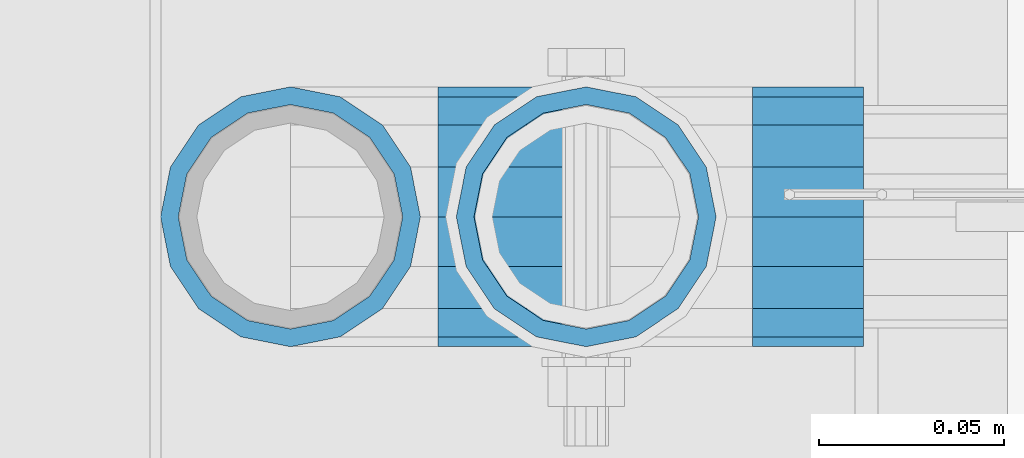
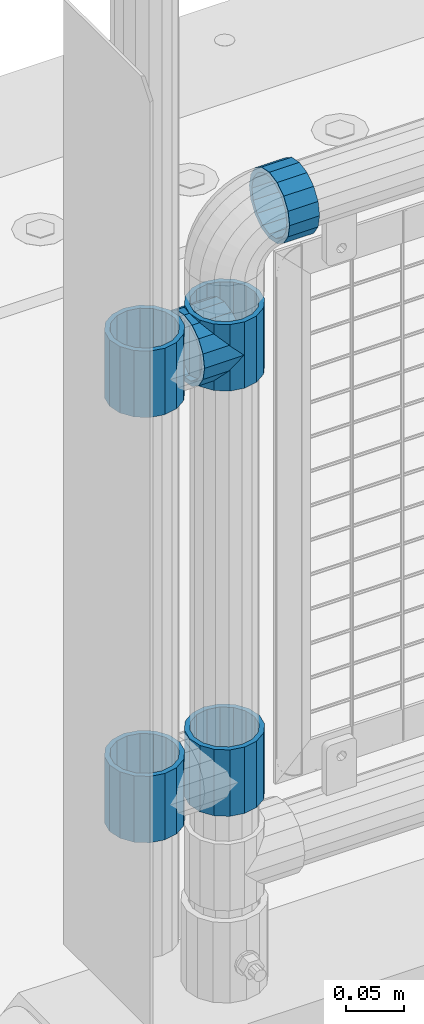
# One storey, part 142 of 242: 6 beams.
"""IFC2X3 building model written with IfcOpenShell, lengths in millimetres."""

import ifcopenshell
import ifcopenshell.guid

model = None  # the IFC model being written
_history = None  # IfcOwnerHistory: only IFC2X3 demands one
_inside = {}  # id of a spatial element -> (the spatial element, [elements in it])
_under = {}  # id of a project, library or spatial element -> (it, [spatial elements below it])
_declared = {}  # id of a project -> (the project, [libraries it declares])
_typed = {}  # id of a type object -> (the type object, [elements of that type])
_made_of = {}  # id of a material, layer set ... -> (it, [elements and type objects made of it])


def new_model(schema):
    """Start an empty IFC model of exactly this schema.

    Asked for "IFC4X3", IfcOpenShell would pick the latest addendum, in which some entities
    have other attributes; the version numbers below select the first issue.
    IFC2X3 requires an IfcOwnerHistory on every rooted entity: one is made here for all.
    """
    global model, _history
    if schema == "IFC4X3":
        model = ifcopenshell.file(schema_version=(4, 3, 0, 0))
    else:
        model = ifcopenshell.file(schema=schema)
    _inside.clear()
    _under.clear()
    _declared.clear()
    _typed.clear()
    _made_of.clear()
    _history = None
    if model.schema == "IFC2X3":
        org = make("IfcOrganization", Name="unknown")
        user = make(
            "IfcPersonAndOrganization",
            ThePerson=make("IfcPerson", FamilyName="unknown"),
            TheOrganization=org,
        )
        app = make(
            "IfcApplication",
            ApplicationDeveloper=org,
            Version="unknown",
            ApplicationFullName="unknown",
            ApplicationIdentifier="unknown",
        )
        _history = make(
            "IfcOwnerHistory",
            OwningUser=user,
            OwningApplication=app,
            ChangeAction="ADDED",
            CreationDate=0,
        )
    return model


def make(cls, **values):
    """One entity of the class cls with the attributes given. An attribute that is None is left unset."""
    return model.create_entity(
        cls, **{name: value for name, value in values.items() if value is not None}
    )


def rooted(cls, **values):
    """An entity with a GlobalId (a new one), such as an element, a storey or a relation."""
    return make(cls, GlobalId=ifcopenshell.guid.new(), OwnerHistory=_history, **values)


def si_unit(unit_type, name, prefix=None):
    """IfcSIUnit, for example si_unit("LENGTHUNIT", "METRE", prefix="MILLI")."""
    return make("IfcSIUnit", UnitType=unit_type, Prefix=prefix, Name=name)


def assignment(units):
    """IfcUnitAssignment: the units of a project."""
    return None if units is None else make("IfcUnitAssignment", Units=units)


def point(xyz):
    """IfcCartesianPoint."""
    return None if xyz is None else make("IfcCartesianPoint", Coordinates=xyz)


def direction(xyz):
    """IfcDirection."""
    return None if xyz is None else make("IfcDirection", DirectionRatios=xyz)


def frame(location, z_axis=None, x_axis=None):
    """IfcAxis2Placement3D, a coordinate frame: its origin and axes. An axis left out is left unset."""
    return make(
        "IfcAxis2Placement3D",
        Location=point(location),
        Axis=direction(z_axis),
        RefDirection=direction(x_axis),
    )


def origin_with_axes():
    """The frame at (0, 0, 0) with the z axis (0, 0, 1) and the x axis (1, 0, 0) written out."""
    return frame((0.0, 0.0, 0.0), z_axis=(0.0, 0.0, 1.0), x_axis=(1.0, 0.0, 0.0))


def place(relative_to, where):
    """IfcLocalPlacement: puts the frame where relative to a parent placement (None: the world)."""
    return make(
        "IfcLocalPlacement", PlacementRelTo=relative_to, RelativePlacement=where
    )


def context(
    kind, dimensions, precision=None, world=None, true_north=None, identifier=None
):
    """IfcGeometricRepresentationContext, for example the 3D "Model" context."""
    return make(
        "IfcGeometricRepresentationContext",
        ContextIdentifier=identifier,
        ContextType=kind,
        CoordinateSpaceDimension=dimensions,
        Precision=precision,
        WorldCoordinateSystem=world,
        TrueNorth=true_north,
    )


def subcontext(parent, identifier, kind, view, scale=None):
    """IfcGeometricRepresentationSubContext, for example "Body" below "Model"."""
    return make(
        "IfcGeometricRepresentationSubContext",
        ContextIdentifier=identifier,
        ContextType=kind,
        ParentContext=parent,
        TargetScale=scale,
        TargetView=view,
    )


def project(units=None, contexts=None):
    """IfcProject with its units and contexts."""
    return rooted(
        "IfcProject",
        Name="project",
        RepresentationContexts=contexts,
        UnitsInContext=assignment(units),
    )


def spatial(cls, under=None, at=None, **own):
    """A site, building, storey or space (cls), placed at a placement, below another one or the project."""
    s = rooted(cls, ObjectPlacement=at, **own)
    if under is not None:
        _under.setdefault(under.id(), (under, []))[1].append(s)
    return s


def faces_of(points, faces, orient=None, outer=None):
    """IfcFace entities. A face is a list of loops; a loop is a list of indices into points, from 0.

    orient and outer hold one flag for each loop. By default every Orientation is true, the
    first loop of a face is its IfcFaceOuterBound and the others are IfcFaceBound.
    """
    made = []
    for i, loops in enumerate(faces):
        bounds = []
        for j, loop in enumerate(loops):
            is_outer = j == 0 if outer is None else outer[i][j]
            bounds.append(
                make(
                    "IfcFaceOuterBound" if is_outer else "IfcFaceBound",
                    Bound=make("IfcPolyLoop", Polygon=[points[k] for k in loop]),
                    Orientation=True if orient is None else orient[i][j],
                )
            )
        made.append(make("IfcFace", Bounds=bounds))
    return made


def faceted_brep(points, faces, orient=None, outer=None, voids=None):
    """IfcFacetedBrep: a solid bounded by flat faces; with voids (closed shells), ...WithVoids."""
    shared = [point(p) for p in points]
    hull = make("IfcClosedShell", CfsFaces=faces_of(shared, faces, orient, outer))
    if voids is None:
        return make("IfcFacetedBrep", Outer=hull)
    return make(
        "IfcFacetedBrepWithVoids",
        Outer=hull,
        Voids=[
            make(cls, CfsFaces=faces_of(shared, fs, o, b)) for cls, fs, o, b in voids
        ],
    )


def shape(context_of_items, identifier, shape_type, items):
    """IfcShapeRepresentation: the items that make up one representation, for example the "Body"."""
    return make(
        "IfcShapeRepresentation",
        ContextOfItems=context_of_items,
        RepresentationIdentifier=identifier,
        RepresentationType=shape_type,
        Items=items,
    )


def material(Name=None, Category=None):
    """IfcMaterial."""
    return make("IfcMaterial", Name=Name, Category=Category)


def made_of(thing, what):
    """Note that an element or type object is made of a material, layer set ...; save() writes the relation."""
    if what is not None:
        _made_of.setdefault(what.id(), (what, []))[1].append(thing)
    return thing


def type_object(cls, material=None, **own):
    """A type object (cls), such as IfcWallType, which elements share."""
    return made_of(rooted(cls, **own), material)


def element(
    cls,
    number,
    at=None,
    inside=None,
    cuts=None,
    type_object=None,
    material=None,
    context=None,
    identifier="Body",
    shape_type=None,
    held_by="IfcProductDefinitionShape",
    body=None,
    shapes=None,
    **own,
):
    """One element of the class cls, such as IfcWall. Its Tag is "e" and its number.

    at: its placement. inside: the storey or other place that contains it. cuts: it is an
    opening in that element (IfcRelVoidsElement). A single representation is given by context,
    identifier, shape_type and body (its items); several are given by shapes. held_by: the class
    of the entity that holds the representations. save() writes the other relations.
    """
    e = rooted(cls, Tag="e%d" % number, ObjectPlacement=at, **own)
    if body is not None:
        shapes = [shape(context, identifier, shape_type, body)]
    if shapes is not None:
        e.Representation = make(held_by, Representations=shapes)
    if inside is not None:
        _inside.setdefault(inside.id(), (inside, []))[1].append(e)
    if cuts is not None:
        rooted(
            "IfcRelVoidsElement", RelatingBuildingElement=cuts, RelatedOpeningElement=e
        )
    if type_object is not None:
        _typed.setdefault(type_object.id(), (type_object, []))[1].append(e)
    return made_of(e, material)


def aggregate(whole, parts):
    """IfcRelAggregates: a whole, such as a stair, and the parts it consists of."""
    return rooted("IfcRelAggregates", RelatingObject=whole, RelatedObjects=parts)


def save(model, path):
    """Write the relations noted so far, then the file.

    IfcRelAggregates (storeys below a building ...), IfcRelContainedInSpatialStructure (elements
    in a storey), IfcRelDefinesByType, IfcRelAssociatesMaterial and IfcRelDeclares: one each for
    every whole, place, type object, material and project.
    """
    for whole, parts in _under.values():
        aggregate(whole, parts)
    for where, things in _inside.values():
        rooted(
            "IfcRelContainedInSpatialStructure",
            RelatedElements=things,
            RelatingStructure=where,
        )
    for kind, things in _typed.values():
        rooted("IfcRelDefinesByType", RelatedObjects=things, RelatingType=kind)
    for what, things in _made_of.values():
        rooted("IfcRelAssociatesMaterial", RelatedObjects=things, RelatingMaterial=what)
    for by, libraries in _declared.values():
        rooted("IfcRelDeclares", RelatingContext=by, RelatedDefinitions=libraries)
    model.write(path)


model = new_model("IFC2X3")

# Units and contexts
model_context = context("Model", 3, precision=1e-05, world=origin_with_axes())
body_context = subcontext(model_context, "Body", "Model", "MODEL_VIEW")
ifc_project = project(units=[si_unit("LENGTHUNIT", "METRE", prefix="MILLI"), si_unit("AREAUNIT", "SQUARE_METRE"), si_unit("VOLUMEUNIT", "CUBIC_METRE"), si_unit("MASSUNIT", "GRAM", prefix="KILO"), si_unit("TIMEUNIT", "SECOND"), si_unit("PLANEANGLEUNIT", "RADIAN"), si_unit("SOLIDANGLEUNIT", "STERADIAN"), si_unit("THERMODYNAMICTEMPERATUREUNIT", "DEGREE_CELSIUS"), si_unit("LUMINOUSINTENSITYUNIT", "LUMEN")], contexts=[model_context])

# Site, building, storey
site_placement = place(None, origin_with_axes())
site = spatial("IfcSite", under=ifc_project, at=site_placement, CompositionType="ELEMENT")
building_placement = place(site_placement, origin_with_axes())
building = spatial("IfcBuilding", under=site, at=building_placement, Name="Standard", CompositionType="ELEMENT")
storey_placement = place(building_placement, origin_with_axes())
storey = spatial("IfcBuildingStorey", under=building, at=storey_placement, Name="Undefined", CompositionType="ELEMENT", Elevation=0.0)

# Beams
ifc_material = material(Name="Misc_Undefined")
beam_type = type_object("IfcBeamType", PredefinedType="NOTDEFINED")
beam_1_placement = place(storey_placement, frame((-41829.0, -19335.5, 848.670000000001), z_axis=(0.0, 1.0, 0.0), x_axis=(-1.0, 0.0, 0.0)))
element("IfcBeam", 1, at=beam_1_placement, inside=storey, type_object=beam_type, material=ifc_material, context=body_context, shape_type="Brep", body=[
    faceted_brep([(0.0, -30.3499999999985, 0.0), (0.0, -28.0397438117179, 11.6144421722784), (40.1500000000015, -28.0397438117175, 11.614442172282), (40.1500000000015, -30.35, 0.0), (0.0, -21.46069080901, 21.4606908090136), (40.1500000000015, -21.4606908090117, 21.46069080901), (0.0, -11.614442172282, 28.0397438117143), (40.1500000000015, -11.6144421722805, 28.0397438117179), (0.0, 0.0, 30.3499999999985), (40.1500000000015, 0.0, 30.3499999999985), (0.0, 11.614442172282, 28.0397438117143), (40.1500000000015, 11.6144421722805, 28.0397438117179), (0.0, 21.46069080901, 21.4606908090136), (40.1500000000015, 21.4606908090117, 21.46069080901), (0.0, 28.0397438117179, 11.6144421722784), (40.1500000000015, 28.0397438117175, 11.614442172282), (0.0, 30.3499999999985, 0.0), (40.1500000000015, 30.35, 0.0), (0.0, 28.0397438117179, -11.6144421722784), (40.1500000000015, 28.0397438117175, -11.614442172282), (0.0, 21.46069080901, -21.4606908090136), (40.1500000000015, 21.4606908090117, -21.46069080901), (0.0, 11.614442172282, -28.0397438117143), (40.1500000000015, 11.6144421722805, -28.0397438117179), (0.0, 0.0, -30.3499999999985), (40.1500000000015, 0.0, -30.3499999999985), (0.0, -11.614442172282, -28.0397438117143), (40.1500000000015, -11.6144421722805, -28.0397438117179), (0.0, -21.46069080901, -21.4606908090136), (40.1500000000015, -21.4606908090117, -21.46069080901), (0.0, -28.0397438117179, -11.6144421722784), (40.1500000000015, -28.0397438117175, -11.614442172282), (0.0, -35.1500000000015, 0.0), (0.0, -32.4743655677703, -13.4513226476338), (40.1500000000015, -32.4743655677717, -13.4513226476338), (40.1500000000015, -35.15, 0.0), (0.0, -24.8548033587067, -24.8548033587067), (40.1500000000015, -24.8548033587072, -24.8548033587067), (0.0, -13.4513226476338, -32.4743655677739), (40.1500000000015, -13.4513226476329, -32.4743655677703), (0.0, 0.0, -35.1500000000015), (40.1500000000015, 0.0, -35.1500000000015), (0.0, 13.4513226476338, -32.4743655677739), (40.1500000000015, 13.4513226476329, -32.4743655677703), (0.0, 24.8548033587067, -24.8548033587067), (40.1500000000015, 24.8548033587072, -24.8548033587067), (0.0, 32.4743655677703, -13.4513226476338), (40.1500000000015, 32.4743655677717, -13.4513226476338), (0.0, 35.1500000000015, 0.0), (40.1500000000015, 35.15, 0.0), (0.0, 32.4743655677703, 13.4513226476338), (40.1500000000015, 32.4743655677717, 13.4513226476338), (0.0, 24.8548033587067, 24.8548033587067), (40.1500000000015, 24.8548033587072, 24.8548033587067), (0.0, 13.4513226476338, 32.4743655677739), (40.1500000000015, 13.4513226476329, 32.4743655677703), (0.0, 0.0, 35.1500000000015), (40.1500000000015, 0.0, 35.1500000000015), (0.0, -13.4513226476338, 32.4743655677739), (40.1500000000015, -13.4513226476329, 32.4743655677703), (0.0, -24.8548033587067, 24.8548033587067), (40.1500000000015, -24.8548033587072, 24.8548033587067), (0.0, -32.4743655677703, 13.4513226476338), (40.1500000000015, -32.4743655677717, 13.4513226476338)], [[[0, 1, 2, 3]], [[1, 4, 5, 2]], [[4, 6, 7, 5]], [[6, 8, 9, 7]], [[8, 10, 11, 9]], [[10, 12, 13, 11]], [[12, 14, 15, 13]], [[14, 16, 17, 15]], [[16, 18, 19, 17]], [[18, 20, 21, 19]], [[20, 22, 23, 21]], [[22, 24, 25, 23]], [[24, 26, 27, 25]], [[26, 28, 29, 27]], [[28, 30, 31, 29]], [[30, 0, 3, 31]], [[32, 33, 34, 35]], [[33, 36, 37, 34]], [[36, 38, 39, 37]], [[38, 40, 41, 39]], [[40, 42, 43, 41]], [[42, 44, 45, 43]], [[44, 46, 47, 45]], [[46, 48, 49, 47]], [[48, 50, 51, 49]], [[50, 52, 53, 51]], [[52, 54, 55, 53]], [[54, 56, 57, 55]], [[56, 58, 59, 57]], [[58, 60, 61, 59]], [[60, 62, 63, 61]], [[62, 32, 35, 63]], [[37, 39, 41, 43, 45, 47, 49, 51, 53, 55, 57, 59, 61, 63, 35, 34], [5, 7, 9, 11, 13, 15, 17, 19, 21, 23, 25, 27, 29, 31, 3, 2]], [[62, 60, 58, 56, 54, 52, 50, 48, 46, 44, 42, 40, 38, 36, 33, 32], [30, 28, 26, 24, 22, 20, 18, 16, 14, 12, 10, 8, 6, 4, 1, 0]]]),
])
beam_2_placement = place(storey_placement, frame((-41784.0, -19335.5, 969.849999999999), z_axis=(0.0, 0.0, 1.0), x_axis=(1.0, 0.0, 0.0)))
element("IfcBeam", 2, at=beam_2_placement, inside=storey, type_object=beam_type, material=ifc_material, context=body_context, shape_type="Brep", body=[
    faceted_brep([(0.0, -30.3499999999985, 0.0), (0.0, -28.0397438117179, 11.6144421722784), (30.0, -28.0397438117179, 11.6144421722805), (30.0, -30.3499999999985, 0.0), (0.0, -21.46069080901, 21.4606908090136), (30.0, -21.46069080901, 21.4606908090117), (0.0, -11.614442172282, 28.0397438117143), (30.0, -11.614442172282, 28.0397438117176), (0.0, 0.0, 30.3499999999985), (30.0, 0.0, 30.35), (0.0, 11.614442172282, 28.0397438117143), (30.0, 11.614442172282, 28.0397438117176), (0.0, 21.46069080901, 21.4606908090136), (30.0, 21.46069080901, 21.4606908090117), (0.0, 28.0397438117179, 11.6144421722784), (30.0, 28.0397438117179, 11.6144421722805), (0.0, 30.3499999999985, 0.0), (30.0, 30.3499999999985, 0.0), (0.0, 28.0397438117179, -11.6144421722784), (30.0, 28.0397438117179, -11.6144421722805), (0.0, 21.46069080901, -21.4606908090136), (30.0, 21.46069080901, -21.4606908090117), (0.0, 11.614442172282, -28.0397438117143), (30.0, 11.614442172282, -28.0397438117176), (0.0, 0.0, -30.3499999999985), (30.0, 0.0, -30.35), (0.0, -11.614442172282, -28.0397438117143), (30.0, -11.614442172282, -28.0397438117176), (0.0, -21.46069080901, -21.4606908090136), (30.0, -21.46069080901, -21.4606908090117), (0.0, -28.0397438117179, -11.6144421722784), (30.0, -28.0397438117179, -11.6144421722805), (0.0, -35.1500000000015, 0.0), (0.0, -32.4743655677703, -13.4513226476338), (30.0, -32.4743655677703, -13.4513226476329), (30.0, -35.1500000000015, 0.0), (0.0, -24.8548033587067, -24.8548033587067), (30.0, -24.8548033587067, -24.8548033587072), (0.0, -13.4513226476338, -32.4743655677739), (30.0, -13.4513226476338, -32.4743655677718), (0.0, 0.0, -35.1500000000015), (30.0, 0.0, -35.15), (0.0, 13.4513226476338, -32.4743655677739), (30.0, 13.4513226476338, -32.4743655677718), (0.0, 24.8548033587067, -24.8548033587067), (30.0, 24.8548033587067, -24.8548033587072), (0.0, 32.4743655677703, -13.4513226476338), (30.0, 32.4743655677703, -13.4513226476329), (0.0, 35.1500000000015, 0.0), (30.0, 35.1500000000015, 0.0), (0.0, 32.4743655677703, 13.4513226476338), (30.0, 32.4743655677703, 13.4513226476329), (0.0, 24.8548033587067, 24.8548033587067), (30.0, 24.8548033587067, 24.8548033587072), (0.0, 13.4513226476338, 32.4743655677739), (30.0, 13.4513226476338, 32.4743655677718), (0.0, 0.0, 35.1500000000015), (30.0, 0.0, 35.15), (0.0, -13.4513226476338, 32.4743655677739), (30.0, -13.4513226476338, 32.4743655677718), (0.0, -24.8548033587067, 24.8548033587067), (30.0, -24.8548033587067, 24.8548033587072), (0.0, -32.4743655677703, 13.4513226476338), (30.0, -32.4743655677703, 13.4513226476329)], [[[0, 1, 2, 3]], [[1, 4, 5, 2]], [[4, 6, 7, 5]], [[6, 8, 9, 7]], [[8, 10, 11, 9]], [[10, 12, 13, 11]], [[12, 14, 15, 13]], [[14, 16, 17, 15]], [[16, 18, 19, 17]], [[18, 20, 21, 19]], [[20, 22, 23, 21]], [[22, 24, 25, 23]], [[24, 26, 27, 25]], [[26, 28, 29, 27]], [[28, 30, 31, 29]], [[30, 0, 3, 31]], [[32, 33, 34, 35]], [[33, 36, 37, 34]], [[36, 38, 39, 37]], [[38, 40, 41, 39]], [[40, 42, 43, 41]], [[42, 44, 45, 43]], [[44, 46, 47, 45]], [[46, 48, 49, 47]], [[48, 50, 51, 49]], [[50, 52, 53, 51]], [[52, 54, 55, 53]], [[54, 56, 57, 55]], [[56, 58, 59, 57]], [[58, 60, 61, 59]], [[60, 62, 63, 61]], [[62, 32, 35, 63]], [[37, 39, 41, 43, 45, 47, 49, 51, 53, 55, 57, 59, 61, 63, 35, 34], [5, 7, 9, 11, 13, 15, 17, 19, 21, 23, 25, 27, 29, 31, 3, 2]], [[62, 60, 58, 56, 54, 52, 50, 48, 46, 44, 42, 40, 38, 36, 33, 32], [30, 28, 26, 24, 22, 20, 18, 16, 14, 12, 10, 8, 6, 4, 1, 0]]]),
])
beam_3_placement = place(storey_placement, frame((-41909.0, -19335.5, 433.819999999999), z_axis=(-1.0, 0.0, 0.0), x_axis=(0.0, 0.0, -1.0)))
element("IfcBeam", 3, at=beam_3_placement, inside=storey, type_object=beam_type, material=ifc_material, context=body_context, shape_type="Brep", body=[
    faceted_brep([(0.0, -30.3499999999985, 0.0), (0.0, -28.0397438117179, 11.6144421722784), (70.2999999999993, -28.0397438117179, 11.6144421722784), (70.2999999999993, -30.3499999999985, 0.0), (0.0, -21.46069080901, 21.4606908090136), (70.2999999999993, -21.46069080901, 21.4606908090136), (0.0, -11.614442172282, 28.0397438117143), (70.2999999999993, -11.614442172282, 28.0397438117143), (0.0, 0.0, 30.3499999999985), (70.2999999999993, 0.0, 30.3499999999985), (0.0, 11.614442172282, 28.0397438117143), (70.2999999999993, 11.614442172282, 28.0397438117143), (0.0, 21.46069080901, 21.4606908090136), (70.2999999999993, 21.46069080901, 21.4606908090136), (0.0, 28.0397438117179, 11.6144421722784), (70.2999999999993, 28.0397438117179, 11.6144421722784), (0.0, 30.3499999999985, 0.0), (70.2999999999993, 30.3499999999985, 0.0), (0.0, 28.0397438117179, -11.6144421722784), (70.2999999999993, 28.0397438117179, -11.6144421722784), (0.0, 21.46069080901, -21.4606908090136), (70.2999999999993, 21.46069080901, -21.4606908090136), (0.0, 11.614442172282, -28.0397438117143), (70.2999999999993, 11.614442172282, -28.0397438117143), (0.0, 0.0, -30.3499999999985), (70.2999999999993, 0.0, -30.3499999999985), (0.0, -11.614442172282, -28.0397438117143), (70.2999999999993, -11.614442172282, -28.0397438117143), (0.0, -21.46069080901, -21.4606908090136), (70.2999999999993, -21.46069080901, -21.4606908090136), (0.0, -28.0397438117179, -11.6144421722784), (70.2999999999993, -28.0397438117179, -11.6144421722784), (0.0, -35.1500000000015, 0.0), (0.0, -32.4743655677703, -13.4513226476338), (70.2999999999993, -32.4743655677703, -13.4513226476338), (70.2999999999993, -35.1500000000015, 0.0), (0.0, -24.8548033587067, -24.8548033587067), (70.2999999999993, -24.8548033587067, -24.8548033587067), (0.0, -13.4513226476338, -32.4743655677739), (70.2999999999993, -13.4513226476338, -32.4743655677739), (0.0, 0.0, -35.1500000000015), (70.2999999999993, 0.0, -35.1500000000015), (0.0, 13.4513226476338, -32.4743655677739), (70.2999999999993, 13.4513226476338, -32.4743655677739), (0.0, 24.8548033587067, -24.8548033587067), (70.2999999999993, 24.8548033587067, -24.8548033587067), (0.0, 32.4743655677703, -13.4513226476338), (70.2999999999993, 32.4743655677703, -13.4513226476338), (0.0, 35.1500000000015, 0.0), (70.2999999999993, 35.1500000000015, 0.0), (0.0, 32.4743655677703, 13.4513226476338), (70.2999999999993, 32.4743655677703, 13.4513226476338), (0.0, 24.8548033587067, 24.8548033587067), (70.2999999999993, 24.8548033587067, 24.8548033587067), (0.0, 13.4513226476338, 32.4743655677739), (70.2999999999993, 13.4513226476338, 32.4743655677739), (0.0, 0.0, 35.1500000000015), (70.2999999999993, 0.0, 35.1500000000015), (0.0, -13.4513226476338, 32.4743655677739), (70.2999999999993, -13.4513226476338, 32.4743655677739), (0.0, -24.8548033587067, 24.8548033587067), (70.2999999999993, -24.8548033587067, 24.8548033587067), (0.0, -32.4743655677703, 13.4513226476338), (70.2999999999993, -32.4743655677703, 13.4513226476338)], [[[0, 1, 2, 3]], [[1, 4, 5, 2]], [[4, 6, 7, 5]], [[6, 8, 9, 7]], [[8, 10, 11, 9]], [[10, 12, 13, 11]], [[12, 14, 15, 13]], [[14, 16, 17, 15]], [[16, 18, 19, 17]], [[18, 20, 21, 19]], [[20, 22, 23, 21]], [[22, 24, 25, 23]], [[24, 26, 27, 25]], [[26, 28, 29, 27]], [[28, 30, 31, 29]], [[30, 0, 3, 31]], [[32, 33, 34, 35]], [[33, 36, 37, 34]], [[36, 38, 39, 37]], [[38, 40, 41, 39]], [[40, 42, 43, 41]], [[42, 44, 45, 43]], [[44, 46, 47, 45]], [[46, 48, 49, 47]], [[48, 50, 51, 49]], [[50, 52, 53, 51]], [[52, 54, 55, 53]], [[54, 56, 57, 55]], [[56, 58, 59, 57]], [[58, 60, 61, 59]], [[60, 62, 63, 61]], [[62, 32, 35, 63]], [[37, 39, 41, 43, 45, 47, 49, 51, 53, 55, 57, 59, 61, 63, 35, 34], [5, 7, 9, 11, 13, 15, 17, 19, 21, 23, 25, 27, 29, 31, 3, 2]], [[62, 60, 58, 56, 54, 52, 50, 48, 46, 44, 42, 40, 38, 36, 33, 32], [30, 28, 26, 24, 22, 20, 18, 16, 14, 12, 10, 8, 6, 4, 1, 0]]]),
])
beam_4_placement = place(storey_placement, frame((-41829.0, -19335.5, 433.819999999999), z_axis=(1.0, 0.0, 0.0), x_axis=(0.0, 0.0, -1.0)))
element("IfcBeam", 4, at=beam_4_placement, inside=storey, type_object=beam_type, material=ifc_material, context=body_context, shape_type="Brep", body=[
    faceted_brep([(0.0, -30.3499999999985, 0.0), (0.0, -28.0397438117179, 11.6144421722784), (70.2999999999993, -28.0397438117179, 11.6144421722784), (70.2999999999993, -30.3499999999985, 0.0), (0.0, -21.46069080901, 21.4606908090136), (70.2999999999993, -21.46069080901, 21.4606908090136), (0.0, -11.614442172282, 28.0397438117143), (70.2999999999993, -11.614442172282, 28.0397438117143), (0.0, 0.0, 30.3499999999985), (70.2999999999993, 0.0, 30.3499999999985), (0.0, 11.614442172282, 28.0397438117143), (70.2999999999993, 11.614442172282, 28.0397438117143), (0.0, 21.46069080901, 21.4606908090136), (70.2999999999993, 21.46069080901, 21.4606908090136), (0.0, 28.0397438117179, 11.6144421722784), (70.2999999999993, 28.0397438117179, 11.6144421722784), (0.0, 30.3499999999985, 0.0), (70.2999999999993, 30.3499999999985, 0.0), (0.0, 28.0397438117179, -11.6144421722784), (70.2999999999993, 28.0397438117179, -11.6144421722784), (0.0, 21.46069080901, -21.4606908090136), (70.2999999999993, 21.46069080901, -21.4606908090136), (0.0, 11.614442172282, -28.0397438117143), (70.2999999999993, 11.614442172282, -28.0397438117143), (0.0, 0.0, -30.3499999999985), (70.2999999999993, 0.0, -30.3499999999985), (0.0, -11.614442172282, -28.0397438117143), (70.2999999999993, -11.614442172282, -28.0397438117143), (0.0, -21.46069080901, -21.4606908090136), (70.2999999999993, -21.46069080901, -21.4606908090136), (0.0, -28.0397438117179, -11.6144421722784), (70.2999999999993, -28.0397438117179, -11.6144421722784), (0.0, -35.1500000000015, 0.0), (0.0, -32.4743655677703, -13.4513226476338), (70.2999999999993, -32.4743655677703, -13.4513226476338), (70.2999999999993, -35.1500000000015, 0.0), (0.0, -24.8548033587067, -24.8548033587067), (70.2999999999993, -24.8548033587067, -24.8548033587067), (0.0, -13.4513226476338, -32.4743655677739), (70.2999999999993, -13.4513226476338, -32.4743655677739), (0.0, 0.0, -35.1500000000015), (70.2999999999993, 0.0, -35.1500000000015), (0.0, 13.4513226476338, -32.4743655677739), (70.2999999999993, 13.4513226476338, -32.4743655677739), (0.0, 24.8548033587067, -24.8548033587067), (70.2999999999993, 24.8548033587067, -24.8548033587067), (0.0, 32.4743655677703, -13.4513226476338), (70.2999999999993, 32.4743655677703, -13.4513226476338), (0.0, 35.1500000000015, 0.0), (70.2999999999993, 35.1500000000015, 0.0), (0.0, 32.4743655677703, 13.4513226476338), (70.2999999999993, 32.4743655677703, 13.4513226476338), (0.0, 24.8548033587067, 24.8548033587067), (70.2999999999993, 24.8548033587067, 24.8548033587067), (0.0, 13.4513226476338, 32.4743655677739), (70.2999999999993, 13.4513226476338, 32.4743655677739), (0.0, 0.0, 35.1500000000015), (70.2999999999993, 0.0, 35.1500000000015), (0.0, -13.4513226476338, 32.4743655677739), (70.2999999999993, -13.4513226476338, 32.4743655677739), (0.0, -24.8548033587067, 24.8548033587067), (70.2999999999993, -24.8548033587067, 24.8548033587067), (0.0, -32.4743655677703, 13.4513226476338), (70.2999999999993, -32.4743655677703, 13.4513226476338)], [[[0, 1, 2, 3]], [[1, 4, 5, 2]], [[4, 6, 7, 5]], [[6, 8, 9, 7]], [[8, 10, 11, 9]], [[10, 12, 13, 11]], [[12, 14, 15, 13]], [[14, 16, 17, 15]], [[16, 18, 19, 17]], [[18, 20, 21, 19]], [[20, 22, 23, 21]], [[22, 24, 25, 23]], [[24, 26, 27, 25]], [[26, 28, 29, 27]], [[28, 30, 31, 29]], [[30, 0, 3, 31]], [[32, 33, 34, 35]], [[33, 36, 37, 34]], [[36, 38, 39, 37]], [[38, 40, 41, 39]], [[40, 42, 43, 41]], [[42, 44, 45, 43]], [[44, 46, 47, 45]], [[46, 48, 49, 47]], [[48, 50, 51, 49]], [[50, 52, 53, 51]], [[52, 54, 55, 53]], [[54, 56, 57, 55]], [[56, 58, 59, 57]], [[58, 60, 61, 59]], [[60, 62, 63, 61]], [[62, 32, 35, 63]], [[37, 39, 41, 43, 45, 47, 49, 51, 53, 55, 57, 59, 61, 63, 35, 34], [5, 7, 9, 11, 13, 15, 17, 19, 21, 23, 25, 27, 29, 31, 3, 2]], [[62, 60, 58, 56, 54, 52, 50, 48, 46, 44, 42, 40, 38, 36, 33, 32], [30, 28, 26, 24, 22, 20, 18, 16, 14, 12, 10, 8, 6, 4, 1, 0]]]),
])
beam_5_placement = place(storey_placement, frame((-41909.0, -19335.5, 883.82), z_axis=(-1.0, 0.0, 0.0), x_axis=(0.0, 0.0, -1.0)))
element("IfcBeam", 5, at=beam_5_placement, inside=storey, type_object=beam_type, material=ifc_material, context=body_context, shape_type="Brep", body=[
    faceted_brep([(0.0, -30.3499999999985, 0.0), (0.0, -28.0397438117179, 11.6144421722784), (70.2999999999993, -28.0397438117179, 11.6144421722784), (70.2999999999993, -30.3499999999985, 0.0), (0.0, -21.46069080901, 21.4606908090136), (70.2999999999993, -21.46069080901, 21.4606908090136), (0.0, -11.614442172282, 28.0397438117143), (70.2999999999993, -11.614442172282, 28.0397438117143), (0.0, 0.0, 30.3499999999985), (70.2999999999993, 0.0, 30.3499999999985), (0.0, 11.614442172282, 28.0397438117143), (70.2999999999993, 11.614442172282, 28.0397438117143), (0.0, 21.46069080901, 21.4606908090136), (70.2999999999993, 21.46069080901, 21.4606908090136), (0.0, 28.0397438117179, 11.6144421722784), (70.2999999999993, 28.0397438117179, 11.6144421722784), (0.0, 30.3499999999985, 0.0), (70.2999999999993, 30.3499999999985, 0.0), (0.0, 28.0397438117179, -11.6144421722784), (70.2999999999993, 28.0397438117179, -11.6144421722784), (0.0, 21.46069080901, -21.4606908090136), (70.2999999999993, 21.46069080901, -21.4606908090136), (0.0, 11.614442172282, -28.0397438117143), (70.2999999999993, 11.614442172282, -28.0397438117143), (0.0, 0.0, -30.3499999999985), (70.2999999999993, 0.0, -30.3499999999985), (0.0, -11.614442172282, -28.0397438117143), (70.2999999999993, -11.614442172282, -28.0397438117143), (0.0, -21.46069080901, -21.4606908090136), (70.2999999999993, -21.46069080901, -21.4606908090136), (0.0, -28.0397438117179, -11.6144421722784), (70.2999999999993, -28.0397438117179, -11.6144421722784), (0.0, -35.1500000000015, 0.0), (0.0, -32.4743655677703, -13.4513226476338), (70.2999999999993, -32.4743655677703, -13.4513226476338), (70.2999999999993, -35.1500000000015, 0.0), (0.0, -24.8548033587067, -24.8548033587067), (70.2999999999993, -24.8548033587067, -24.8548033587067), (0.0, -13.4513226476338, -32.4743655677739), (70.2999999999993, -13.4513226476338, -32.4743655677739), (0.0, 0.0, -35.1500000000015), (70.2999999999993, 0.0, -35.1500000000015), (0.0, 13.4513226476338, -32.4743655677739), (70.2999999999993, 13.4513226476338, -32.4743655677739), (0.0, 24.8548033587067, -24.8548033587067), (70.2999999999993, 24.8548033587067, -24.8548033587067), (0.0, 32.4743655677703, -13.4513226476338), (70.2999999999993, 32.4743655677703, -13.4513226476338), (0.0, 35.1500000000015, 0.0), (70.2999999999993, 35.1500000000015, 0.0), (0.0, 32.4743655677703, 13.4513226476338), (70.2999999999993, 32.4743655677703, 13.4513226476338), (0.0, 24.8548033587067, 24.8548033587067), (70.2999999999993, 24.8548033587067, 24.8548033587067), (0.0, 13.4513226476338, 32.4743655677739), (70.2999999999993, 13.4513226476338, 32.4743655677739), (0.0, 0.0, 35.1500000000015), (70.2999999999993, 0.0, 35.1500000000015), (0.0, -13.4513226476338, 32.4743655677739), (70.2999999999993, -13.4513226476338, 32.4743655677739), (0.0, -24.8548033587067, 24.8548033587067), (70.2999999999993, -24.8548033587067, 24.8548033587067), (0.0, -32.4743655677703, 13.4513226476338), (70.2999999999993, -32.4743655677703, 13.4513226476338)], [[[0, 1, 2, 3]], [[1, 4, 5, 2]], [[4, 6, 7, 5]], [[6, 8, 9, 7]], [[8, 10, 11, 9]], [[10, 12, 13, 11]], [[12, 14, 15, 13]], [[14, 16, 17, 15]], [[16, 18, 19, 17]], [[18, 20, 21, 19]], [[20, 22, 23, 21]], [[22, 24, 25, 23]], [[24, 26, 27, 25]], [[26, 28, 29, 27]], [[28, 30, 31, 29]], [[30, 0, 3, 31]], [[32, 33, 34, 35]], [[33, 36, 37, 34]], [[36, 38, 39, 37]], [[38, 40, 41, 39]], [[40, 42, 43, 41]], [[42, 44, 45, 43]], [[44, 46, 47, 45]], [[46, 48, 49, 47]], [[48, 50, 51, 49]], [[50, 52, 53, 51]], [[52, 54, 55, 53]], [[54, 56, 57, 55]], [[56, 58, 59, 57]], [[58, 60, 61, 59]], [[60, 62, 63, 61]], [[62, 32, 35, 63]], [[37, 39, 41, 43, 45, 47, 49, 51, 53, 55, 57, 59, 61, 63, 35, 34], [5, 7, 9, 11, 13, 15, 17, 19, 21, 23, 25, 27, 29, 31, 3, 2]], [[62, 60, 58, 56, 54, 52, 50, 48, 46, 44, 42, 40, 38, 36, 33, 32], [30, 28, 26, 24, 22, 20, 18, 16, 14, 12, 10, 8, 6, 4, 1, 0]]]),
])
beam_6_placement = place(storey_placement, frame((-41829.0, -19335.5, 883.82), z_axis=(1.0, 0.0, 0.0), x_axis=(0.0, 0.0, -1.0)))
element("IfcBeam", 6, at=beam_6_placement, inside=storey, type_object=beam_type, material=ifc_material, context=body_context, shape_type="Brep", body=[
    faceted_brep([(0.0, -30.3499999999985, 0.0), (0.0, -28.0397438117179, 11.6144421722784), (70.2999999999993, -28.0397438117179, 11.6144421722784), (70.2999999999993, -30.3499999999985, 0.0), (0.0, -21.46069080901, 21.4606908090136), (70.2999999999993, -21.46069080901, 21.4606908090136), (0.0, -11.614442172282, 28.0397438117143), (70.2999999999993, -11.614442172282, 28.0397438117143), (0.0, 0.0, 30.3499999999985), (70.2999999999993, 0.0, 30.3499999999985), (0.0, 11.614442172282, 28.0397438117143), (70.2999999999993, 11.614442172282, 28.0397438117143), (0.0, 21.46069080901, 21.4606908090136), (70.2999999999993, 21.46069080901, 21.4606908090136), (0.0, 28.0397438117179, 11.6144421722784), (70.2999999999993, 28.0397438117179, 11.6144421722784), (0.0, 30.3499999999985, 0.0), (70.2999999999993, 30.3499999999985, 0.0), (0.0, 28.0397438117179, -11.6144421722784), (70.2999999999993, 28.0397438117179, -11.6144421722784), (0.0, 21.46069080901, -21.4606908090136), (70.2999999999993, 21.46069080901, -21.4606908090136), (0.0, 11.614442172282, -28.0397438117143), (70.2999999999993, 11.614442172282, -28.0397438117143), (0.0, 0.0, -30.3499999999985), (70.2999999999993, 0.0, -30.3499999999985), (0.0, -11.614442172282, -28.0397438117143), (70.2999999999993, -11.614442172282, -28.0397438117143), (0.0, -21.46069080901, -21.4606908090136), (70.2999999999993, -21.46069080901, -21.4606908090136), (0.0, -28.0397438117179, -11.6144421722784), (70.2999999999993, -28.0397438117179, -11.6144421722784), (0.0, -35.1500000000015, 0.0), (0.0, -32.4743655677703, -13.4513226476338), (70.2999999999993, -32.4743655677703, -13.4513226476338), (70.2999999999993, -35.1500000000015, 0.0), (0.0, -24.8548033587067, -24.8548033587067), (70.2999999999993, -24.8548033587067, -24.8548033587067), (0.0, -13.4513226476338, -32.4743655677739), (70.2999999999993, -13.4513226476338, -32.4743655677739), (0.0, 0.0, -35.1500000000015), (70.2999999999993, 0.0, -35.1500000000015), (0.0, 13.4513226476338, -32.4743655677739), (70.2999999999993, 13.4513226476338, -32.4743655677739), (0.0, 24.8548033587067, -24.8548033587067), (70.2999999999993, 24.8548033587067, -24.8548033587067), (0.0, 32.4743655677703, -13.4513226476338), (70.2999999999993, 32.4743655677703, -13.4513226476338), (0.0, 35.1500000000015, 0.0), (70.2999999999993, 35.1500000000015, 0.0), (0.0, 32.4743655677703, 13.4513226476338), (70.2999999999993, 32.4743655677703, 13.4513226476338), (0.0, 24.8548033587067, 24.8548033587067), (70.2999999999993, 24.8548033587067, 24.8548033587067), (0.0, 13.4513226476338, 32.4743655677739), (70.2999999999993, 13.4513226476338, 32.4743655677739), (0.0, 0.0, 35.1500000000015), (70.2999999999993, 0.0, 35.1500000000015), (0.0, -13.4513226476338, 32.4743655677739), (70.2999999999993, -13.4513226476338, 32.4743655677739), (0.0, -24.8548033587067, 24.8548033587067), (70.2999999999993, -24.8548033587067, 24.8548033587067), (0.0, -32.4743655677703, 13.4513226476338), (70.2999999999993, -32.4743655677703, 13.4513226476338)], [[[0, 1, 2, 3]], [[1, 4, 5, 2]], [[4, 6, 7, 5]], [[6, 8, 9, 7]], [[8, 10, 11, 9]], [[10, 12, 13, 11]], [[12, 14, 15, 13]], [[14, 16, 17, 15]], [[16, 18, 19, 17]], [[18, 20, 21, 19]], [[20, 22, 23, 21]], [[22, 24, 25, 23]], [[24, 26, 27, 25]], [[26, 28, 29, 27]], [[28, 30, 31, 29]], [[30, 0, 3, 31]], [[32, 33, 34, 35]], [[33, 36, 37, 34]], [[36, 38, 39, 37]], [[38, 40, 41, 39]], [[40, 42, 43, 41]], [[42, 44, 45, 43]], [[44, 46, 47, 45]], [[46, 48, 49, 47]], [[48, 50, 51, 49]], [[50, 52, 53, 51]], [[52, 54, 55, 53]], [[54, 56, 57, 55]], [[56, 58, 59, 57]], [[58, 60, 61, 59]], [[60, 62, 63, 61]], [[62, 32, 35, 63]], [[37, 39, 41, 43, 45, 47, 49, 51, 53, 55, 57, 59, 61, 63, 35, 34], [5, 7, 9, 11, 13, 15, 17, 19, 21, 23, 25, 27, 29, 31, 3, 2]], [[62, 60, 58, 56, 54, 52, 50, 48, 46, 44, 42, 40, 38, 36, 33, 32], [30, 28, 26, 24, 22, 20, 18, 16, 14, 12, 10, 8, 6, 4, 1, 0]]]),
])

save(model, "model.ifc")
